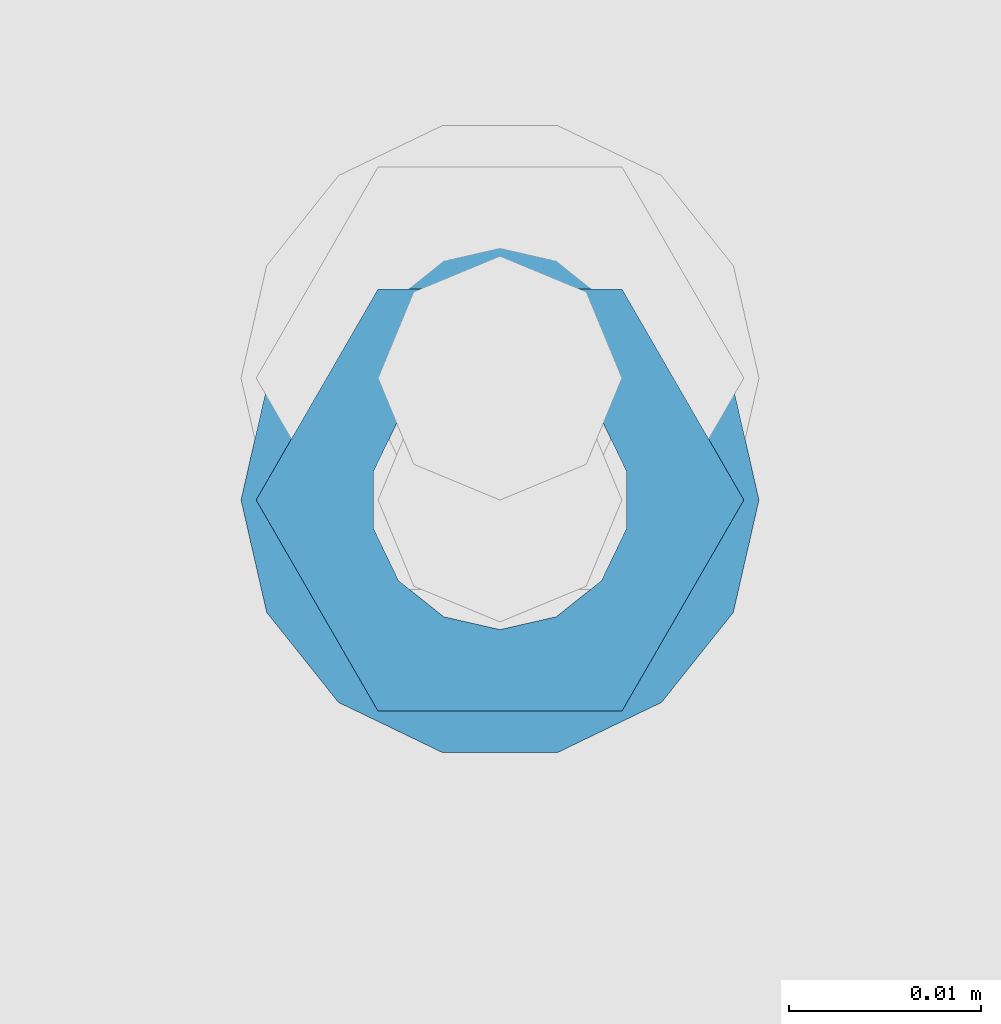
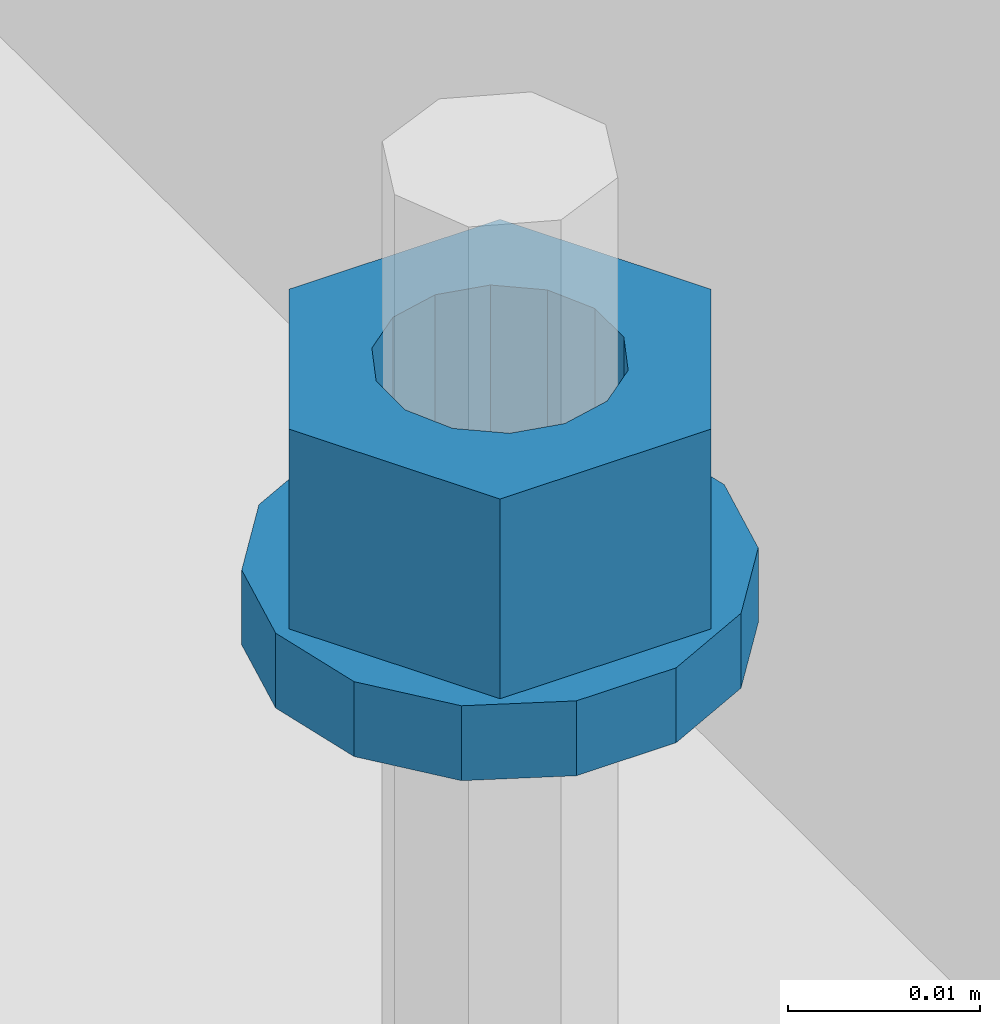
# One storey, part 675 of 1179: 2 columns, 1 element without a shape of its own.
"""IFC2X3 building model written with IfcOpenShell, lengths in millimetres."""

from ifc_helpers import new_model, si_unit, frame, origin_with_axes, place, context, subcontext, project, spatial, faceted_brep, material, type_object, element, aggregate, save


model = new_model("IFC2X3")

# Units and contexts
model_context = context("Model", 3, precision=1e-05, world=origin_with_axes())
body_context = subcontext(model_context, "Body", "Model", "MODEL_VIEW")
ifc_project = project(units=[si_unit("LENGTHUNIT", "METRE", prefix="MILLI"), si_unit("AREAUNIT", "SQUARE_METRE"), si_unit("VOLUMEUNIT", "CUBIC_METRE"), si_unit("MASSUNIT", "GRAM", prefix="KILO"), si_unit("TIMEUNIT", "SECOND"), si_unit("PLANEANGLEUNIT", "RADIAN"), si_unit("SOLIDANGLEUNIT", "STERADIAN"), si_unit("THERMODYNAMICTEMPERATUREUNIT", "DEGREE_CELSIUS"), si_unit("LUMINOUSINTENSITYUNIT", "LUMEN")], contexts=[model_context])

# Site, building, storey
site_placement = place(None, origin_with_axes())
site = spatial("IfcSite", under=ifc_project, at=site_placement, CompositionType="ELEMENT")
building_placement = place(site_placement, origin_with_axes())
building = spatial("IfcBuilding", under=site, at=building_placement, Name="Undefined", CompositionType="ELEMENT")
storey_placement = place(building_placement, origin_with_axes())
storey = spatial("IfcBuildingStorey", under=building, at=storey_placement, Name="Undefined", CompositionType="ELEMENT", Elevation=0.0)

# Assembly, columns
assembly_placement = place(storey_placement, origin_with_axes())
assembly = element("IfcElementAssembly", 1, at=assembly_placement, inside=storey, Name="BEAM", AssemblyPlace="NOTDEFINED", PredefinedType="RIGID_FRAME")
ifc_material = material(Name="STEEL/A307")
column_type_1 = type_object("IfcColumnType", Name="1/2_WASHER", PredefinedType="NOTDEFINED")
column_1_placement = place(assembly_placement, frame((24638.0, 32854.90025, 4235.45), z_axis=(0.0, 1.0, 0.0), x_axis=(0.0, 0.0, 1.0)))
column_1 = element("IfcColumn", 2, at=column_1_placement, type_object=column_type_1, material=ifc_material, Name="WASHER", ObjectType="1/2_WASHER", context=body_context, shape_type="Brep", body=[
    faceted_brep([(0.0, -13.4899997711182, 0.0), (0.0, -12.1540698217868, -5.85309154138758), (4.76249999999891, -12.1540698217868, -5.85309154138758), (4.76249999999891, -13.4899997711182, 0.0), (0.0, -8.41087728436833, -10.5469065195466), (4.76249999999891, -8.41087728436833, -10.5469065195466), (0.0, -3.00180734814057, -13.1517773121896), (4.76249999999891, -3.00180734814057, -13.1517773121896), (0.0, 3.00180734814057, -13.1517773121896), (4.76249999999891, 3.00180734814057, -13.1517773121896), (0.0, 8.41087728436833, -10.5469065195466), (4.76249999999891, 8.41087728436833, -10.5469065195466), (0.0, 12.1540698217868, -5.85309154138758), (4.76249999999891, 12.1540698217868, -5.85309154138758), (0.0, 13.4899997711182, 0.0), (4.76249999999891, 13.4899997711182, 0.0), (0.0, 12.1540698217868, 5.85309154138758), (4.76249999999891, 12.1540698217868, 5.85309154138758), (0.0, 8.41087728436833, 10.5469065195466), (4.76249999999891, 8.41087728436833, 10.5469065195466), (0.0, 3.00180734814057, 13.1517773121896), (4.76249999999891, 3.00180734814057, 13.1517773121896), (0.0, -3.00180734814057, 13.1517773121896), (4.76249999999891, -3.00180734814057, 13.1517773121896), (0.0, -8.41087728436833, 10.5469065195466), (4.76249999999891, -8.41087728436833, 10.5469065195466), (0.0, -12.1540698217868, 5.85309154138758), (4.76249999999891, -12.1540698217868, 5.85309154138758), (0.0, 0.0, 6.75), (0.0, 2.9287152390425, 6.08153985834178), (4.76249999999891, 2.9287152390425, 6.08153985834178), (4.76249999999891, 0.0, 6.75), (0.0, 5.27736250665839, 4.2085561625463), (4.76249999999891, 5.27736250665839, 4.2085561625463), (0.0, 6.58076340722619, 1.50201630420543), (4.76249999999891, 6.58076340722619, 1.50201630420543), (0.0, 6.58076340722619, -1.50201630420543), (4.76249999999891, 6.58076340722619, -1.50201630420543), (0.0, 5.27736250665839, -4.2085561625463), (4.76249999999891, 5.27736250665839, -4.2085561625463), (0.0, 2.9287152390425, -6.08153985834088), (4.76249999999891, 2.9287152390425, -6.08153985834088), (0.0, 0.0, -6.75), (4.76249999999891, 0.0, -6.75), (0.0, -2.9287152390425, -6.08153985834178), (4.76249999999891, -2.9287152390425, -6.08153985834178), (0.0, -5.27736250665839, -4.2085561625463), (4.76249999999891, -5.27736250665839, -4.2085561625463), (0.0, -6.58076340722619, -1.50201630420543), (4.76249999999891, -6.58076340722619, -1.50201630420543), (0.0, -6.58076340722619, 1.50201630420543), (4.76249999999891, -6.58076340722619, 1.50201630420543), (0.0, -5.27736250665839, 4.2085561625463), (4.76249999999891, -5.27736250665839, 4.2085561625463), (0.0, -2.9287152390425, 6.08153985834088), (4.76249999999891, -2.9287152390425, 6.08153985834088)], [[[0, 1, 2, 3]], [[1, 4, 5, 2]], [[4, 6, 7, 5]], [[6, 8, 9, 7]], [[8, 10, 11, 9]], [[10, 12, 13, 11]], [[12, 14, 15, 13]], [[14, 16, 17, 15]], [[16, 18, 19, 17]], [[18, 20, 21, 19]], [[20, 22, 23, 21]], [[22, 24, 25, 23]], [[24, 26, 27, 25]], [[26, 0, 3, 27]], [[28, 29, 30, 31]], [[29, 32, 33, 30]], [[32, 34, 35, 33]], [[34, 36, 37, 35]], [[36, 38, 39, 37]], [[38, 40, 41, 39]], [[40, 42, 43, 41]], [[42, 44, 45, 43]], [[44, 46, 47, 45]], [[46, 48, 49, 47]], [[48, 50, 51, 49]], [[50, 52, 53, 51]], [[52, 54, 55, 53]], [[54, 28, 31, 55]], [[5, 7, 9, 11, 13, 15, 17, 19, 21, 23, 25, 27, 3, 2], [33, 35, 37, 39, 41, 43, 45, 47, 49, 51, 53, 55, 31, 30]], [[26, 24, 22, 20, 18, 16, 14, 12, 10, 8, 6, 4, 1, 0], [54, 52, 50, 48, 46, 44, 42, 40, 38, 36, 34, 32, 29, 28]]]),
])
column_type_2 = type_object("IfcColumnType", Name="1/2_HEAVY_HEX_NUT", PredefinedType="NOTDEFINED")
column_2_placement = place(assembly_placement, frame((24638.0, 32854.90025, 4240.2125), z_axis=(0.0, 1.0, 0.0), x_axis=(0.0, 0.0, 1.0)))
column_2 = element("IfcColumn", 3, at=column_2_placement, type_object=column_type_2, material=ifc_material, Name="NUT", ObjectType="1/2_HEAVY_HEX_NUT", context=body_context, shape_type="Brep", body=[
    faceted_brep([(0.0, -12.7, 0.0), (0.0, -6.34999990463257, -11.0), (12.7000000000007, -6.34999990463257, -11.0), (12.7000000000007, -12.6999998092651, 0.0), (0.0, 6.34999990463257, -11.0), (12.7000000000007, 6.34999990463257, -11.0), (0.0, 12.7, 0.0), (12.7000000000007, 12.6999998092651, 0.0), (0.0, 6.34999990463257, 11.0), (12.7000000000007, 6.34999990463257, 11.0), (0.0, -6.34999990463257, 11.0), (12.7000000000007, -6.34999990463257, 11.0), (0.0, 0.0, 6.75), (0.0, 2.9287152390425, 6.08153985834178), (12.7000000000007, 2.9287152390425, 6.08153985834178), (12.7000000000007, 0.0, 6.75), (0.0, 5.27736250665839, 4.2085561625463), (12.7000000000007, 5.27736250665839, 4.2085561625463), (0.0, 6.58076340722619, 1.50201630420543), (12.7000000000007, 6.58076340722619, 1.50201630420543), (0.0, 6.58076340722619, -1.50201630420543), (12.7000000000007, 6.58076340722619, -1.50201630420543), (0.0, 5.27736250665839, -4.2085561625463), (12.7000000000007, 5.27736250665839, -4.2085561625463), (0.0, 2.9287152390425, -6.08153985834088), (12.7000000000007, 2.9287152390425, -6.08153985834088), (0.0, 0.0, -6.75), (12.7000000000007, 0.0, -6.75), (0.0, -2.9287152390425, -6.08153985834178), (12.7000000000007, -2.9287152390425, -6.08153985834178), (0.0, -5.27736250665839, -4.2085561625463), (12.7000000000007, -5.27736250665839, -4.2085561625463), (0.0, -6.58076340722619, -1.50201630420543), (12.7000000000007, -6.58076340722619, -1.50201630420543), (0.0, -6.58076340722619, 1.50201630420543), (12.7000000000007, -6.58076340722619, 1.50201630420543), (0.0, -5.27736250665839, 4.2085561625463), (12.7000000000007, -5.27736250665839, 4.2085561625463), (0.0, -2.9287152390425, 6.08153985834088), (12.7000000000007, -2.9287152390425, 6.08153985834088)], [[[0, 1, 2, 3]], [[1, 4, 5, 2]], [[4, 6, 7, 5]], [[6, 8, 9, 7]], [[8, 10, 11, 9]], [[10, 0, 3, 11]], [[12, 13, 14, 15]], [[13, 16, 17, 14]], [[16, 18, 19, 17]], [[18, 20, 21, 19]], [[20, 22, 23, 21]], [[22, 24, 25, 23]], [[24, 26, 27, 25]], [[26, 28, 29, 27]], [[28, 30, 31, 29]], [[30, 32, 33, 31]], [[32, 34, 35, 33]], [[34, 36, 37, 35]], [[36, 38, 39, 37]], [[38, 12, 15, 39]], [[5, 7, 9, 11, 3, 2], [17, 19, 21, 23, 25, 27, 29, 31, 33, 35, 37, 39, 15, 14]], [[10, 8, 6, 4, 1, 0], [38, 36, 34, 32, 30, 28, 26, 24, 22, 20, 18, 16, 13, 12]]]),
])
aggregate(assembly, [column_1, column_2])

save(model, "model.ifc")
